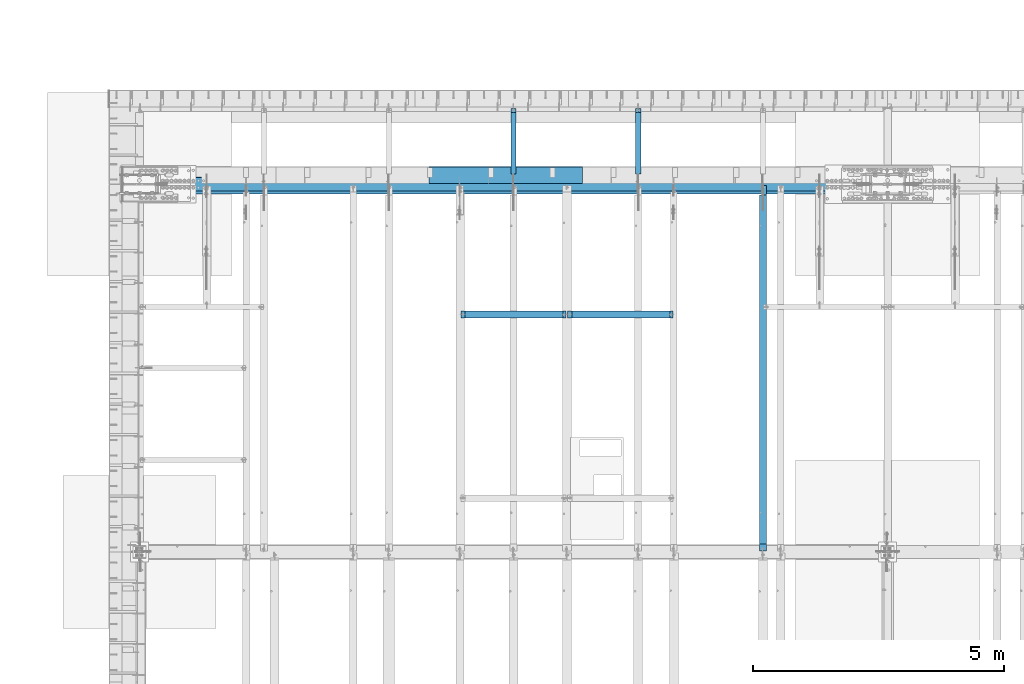
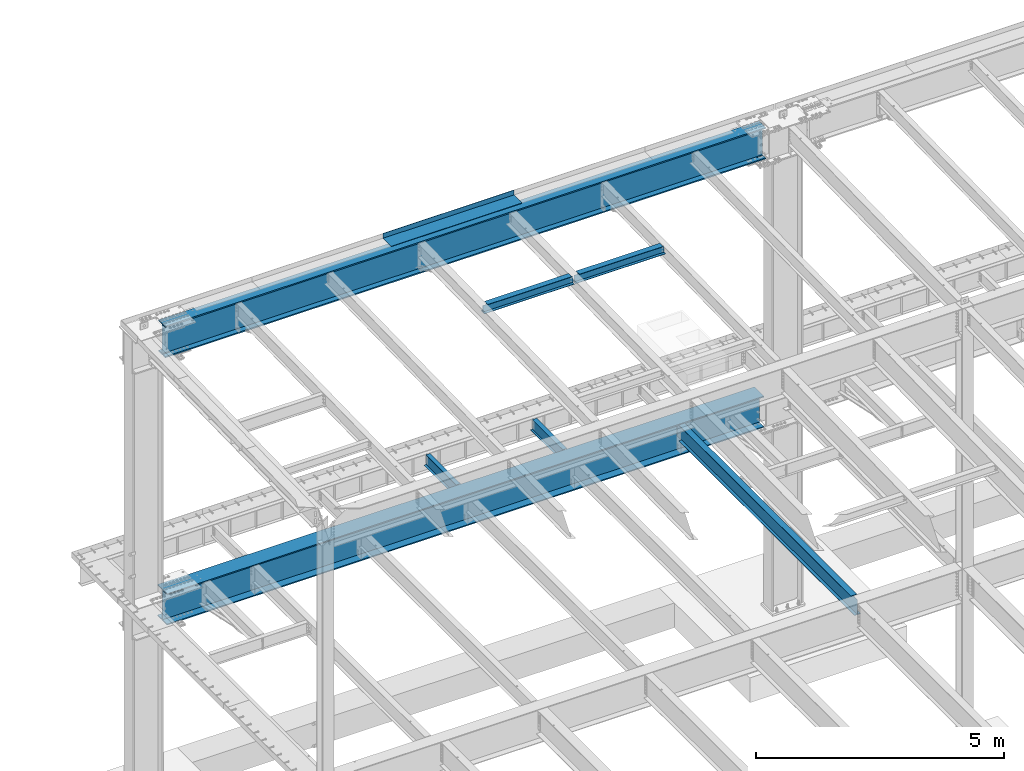
# One storey, part 1127 of 1763: 8 beams, 7 elements without a shape of their own.
"""IFC2X3 building model written with IfcOpenShell, lengths in millimetres."""

from ifc_helpers import new_model, si_unit, frame, origin_with_axes, place, context, subcontext, project, spatial, faceted_brep, material, type_object, element, aggregate, save


model = new_model("IFC2X3")

# Units and contexts
model_context = context("Model", 3, precision=1e-05, world=origin_with_axes())
body_context = subcontext(model_context, "Body", "Model", "MODEL_VIEW")
ifc_project = project(units=[si_unit("LENGTHUNIT", "METRE", prefix="MILLI"), si_unit("AREAUNIT", "SQUARE_METRE"), si_unit("VOLUMEUNIT", "CUBIC_METRE"), si_unit("MASSUNIT", "GRAM", prefix="KILO"), si_unit("TIMEUNIT", "SECOND"), si_unit("PLANEANGLEUNIT", "RADIAN"), si_unit("SOLIDANGLEUNIT", "STERADIAN"), si_unit("THERMODYNAMICTEMPERATUREUNIT", "DEGREE_CELSIUS"), si_unit("LUMINOUSINTENSITYUNIT", "LUMEN")], contexts=[model_context])

# Site, building, storey
site_placement = place(None, origin_with_axes())
site = spatial("IfcSite", under=ifc_project, at=site_placement, CompositionType="ELEMENT")
building_placement = place(site_placement, origin_with_axes())
building = spatial("IfcBuilding", under=site, at=building_placement, Name="Undefined", CompositionType="ELEMENT")
storey_placement = place(building_placement, origin_with_axes())
storey = spatial("IfcBuildingStorey", under=building, at=storey_placement, Name="Undefined", CompositionType="ELEMENT", Elevation=0.0)

# Assembly, beam
assembly_1_placement = place(storey_placement, origin_with_axes())
assembly_1 = element("IfcElementAssembly", 1, at=assembly_1_placement, inside=storey, Name="BEAM", AssemblyPlace="NOTDEFINED", PredefinedType="RIGID_FRAME")
ifc_material_1 = material(Name="STEEL/A992")
beam_type_1 = type_object("IfcBeamType", Name="W8X18", PredefinedType="NOTDEFINED")
beam_1_placement = place(assembly_1_placement, frame((-80902.2926318412, 49529.603125, 11592.1111170495), z_axis=(0.0, 0.0, 1.0), x_axis=(1.0, 0.0, 0.0)))
beam_1 = element("IfcBeam", 2, at=beam_1_placement, type_object=beam_type_1, material=ifc_material_1, Name="BEAM", ObjectType="W8X18", context=body_context, shape_type="Brep", body=[
    faceted_brep([(1960.42688668017, -3.17500000386644, 68.5472454981009), (1960.42688668019, 3.1749999961321, 68.5472454981009), (1959.56590192083, 3.17499999613938, 69.8358002505338), (1959.56590177228, -3.17500000385917, 69.8358004728379), (1964.54706314833, -3.17500000387372, 65.7942315976234), (1964.54706314833, 3.17499999612482, 65.7942315976234), (1969.40714266637, -3.175000003881, 64.8275016750358), (1969.40714266639, 3.17499999611755, 64.8275016750358), (2015.44464294919, -3.17500000397558, 64.8275016750358), (2015.44464276504, 3.17499999602296, 64.8275016750358), (1958.83938981475, -3.17500000385917, 70.3212402430472), (1958.83938963059, 3.17499999613938, 70.3212402430472), (1956.08637573011, 3.17499999613938, 74.4414167112009), (1956.08637591427, -3.17500000385917, 74.4414167112009), (1955.11964580753, 3.17499999614665, 79.3014962292473), (1955.11964599168, -3.17500000385917, 79.3014962292473), (3.17499685616349, 3.17499999998836, 95.25), (3.17499501466227, 66.6749999999884, 95.25), (1955.11964396603, 66.6749999961467, 95.25), (1955.11964580753, 3.17499999614665, 95.25), (3.17499888181919, -66.6750000000102, 103.1875), (3.17499888181919, -66.6750000000102, 95.25), (1955.11964783318, -66.6750000038592, 95.25), (1955.11964783318, -66.6750000038592, 103.1875), (3.17499501466227, 66.6749999999884, 103.1875), (1955.11964396603, 66.6749999961467, 103.1875), (1955.11964599168, -3.17500000385917, 95.25), (3.17499704031798, -3.17500000001019, 95.25), (3.17499685616349, 3.17499999998836, 79.3014961863064), (3.17499704031798, -3.17500000001019, 79.3014961863064), (2.20826693357958, 3.17499999998836, 74.44141666826), (2.20826711773407, -3.17500000001019, 74.44141666826), (-0.544746966901585, 3.17499999999563, 70.3212402001063), (-0.544746782747097, -3.17500000000291, 70.3212402001063), (-1.27125895427889, 3.17499999999563, 69.83580040995), (-1.27125910282484, -3.17500000000291, 69.8358001876459), (-2.13224382305634, 3.17499999999563, 68.5472454937626), (-2.13224382307089, -3.17500000000291, 68.5472454937626), (-6.25242029121728, 3.17500000001019, 65.7942315932851), (-6.25242029121728, -3.17499999998836, 65.7942315932851), (-11.1124998092564, 3.17500000001746, 64.8275016706975), (-11.112499809271, -3.17499999998108, 64.8275016706975), (-79.3750000920845, 3.17500000014843, 64.8275016706975), (-79.37499990793, -3.17499999985012, 64.8275016706975), (-79.3750000920845, 3.17500000014843, -95.25), (-79.3750019335857, 66.6750000001484, -95.25), (-79.3750019335857, 66.6750000001484, -103.1875), (-79.3749980664288, -66.6749999998501, -103.1875), (-79.3749980664288, -66.6749999998501, -95.25), (-79.37499990793, -3.17499999985012, -95.25), (2015.44464276504, 3.17499999602296, -95.25), (2015.44464092355, 66.674999996023, -95.25), (2015.44464092355, 66.674999996023, -103.1875), (2015.4446447907, -66.6750000039756, -103.1875), (2015.4446447907, -66.6750000039756, -95.25), (2015.44464294919, -3.17500000397558, -95.25)], [[[0, 1, 2, 3]], [[4, 5, 1, 0]], [[6, 7, 5, 4]], [[8, 9, 7, 6]], [[10, 11, 12, 13]], [[13, 12, 14, 15]], [[16, 17, 18, 19]], [[20, 21, 22, 23]], [[24, 20, 23, 25]], [[17, 24, 25, 18]], [[23, 22, 26, 15, 14, 19, 18, 25]], [[21, 27, 26, 22]], [[20, 24, 17, 16, 28, 29, 27, 21]], [[29, 28, 30, 31]], [[31, 30, 32, 33]], [[33, 32, 34, 35]], [[35, 34, 36, 37]], [[37, 36, 38, 39]], [[39, 38, 40, 41]], [[41, 40, 42, 43]], [[44, 45, 46, 47, 48, 49, 43, 42]], [[45, 44, 50, 51]], [[46, 45, 51, 52]], [[47, 46, 52, 53]], [[48, 47, 53, 54]], [[49, 48, 54, 55]], [[4, 0, 3, 10, 13, 15, 26, 27, 29, 31, 33, 35, 37, 39, 41, 43, 49, 55, 8, 6]], [[11, 10, 3, 2]], [[50, 44, 42, 40, 38, 36, 34, 32, 30, 28, 16, 19, 14, 12, 11, 2, 1, 5, 7, 9]], [[55, 54, 53, 52, 51, 50, 9, 8]]]),
])
aggregate(assembly_1, [beam_1])

assembly_2_placement = place(storey_placement, origin_with_axes())
assembly_2 = element("IfcElementAssembly", 3, at=assembly_2_placement, inside=storey, Name="BEAM", AssemblyPlace="NOTDEFINED", PredefinedType="RIGID_FRAME")
beam_2_placement = place(assembly_2_placement, frame((-78775.0426318412, 49529.603125, 11592.1111170495), z_axis=(0.0, 0.0, 1.0), x_axis=(1.0, 0.0, 0.0)))
beam_2 = element("IfcBeam", 4, at=beam_2_placement, type_object=beam_type_1, material=ifc_material_1, Name="BEAM", ObjectType="W8X18", context=body_context, shape_type="Brep", body=[
    faceted_brep([(1960.42688668017, -3.17500000386644, 68.5472454981009), (1960.42688668019, 3.1749999961321, 68.5472454981009), (1959.56590192083, 3.17499999613938, 69.8358002505338), (1959.56590177228, -3.17500000385917, 69.8358004728379), (1964.54706314833, -3.17500000387372, 65.7942315976234), (1964.54706314833, 3.17499999612482, 65.7942315976234), (1969.40714266637, -3.175000003881, 64.8275016750358), (1969.40714266639, 3.17499999611755, 64.8275016750358), (2015.44464294919, -3.17500000397558, 64.8275016750358), (2015.44464276504, 3.17499999602296, 64.8275016750358), (1958.83938981475, -3.17500000385917, 70.3212402430472), (1958.83938963059, 3.17499999613938, 70.3212402430472), (1956.08637573011, 3.17499999613938, 74.4414167112009), (1956.08637591427, -3.17500000385917, 74.4414167112009), (1955.11964580753, 3.17499999614665, 79.3014962292473), (1955.11964599168, -3.17500000385917, 79.3014962292473), (3.17499685616349, 3.17499999998836, 95.25), (3.17499501466227, 66.6749999999884, 95.25), (1955.11964396603, 66.6749999961467, 95.25), (1955.11964580753, 3.17499999614665, 95.25), (3.17499888181919, -66.6750000000102, 103.1875), (3.17499888181919, -66.6750000000102, 95.25), (1955.11964783318, -66.6750000038592, 95.25), (1955.11964783318, -66.6750000038592, 103.1875), (3.17499501466227, 66.6749999999884, 103.1875), (1955.11964396603, 66.6749999961467, 103.1875), (1955.11964599168, -3.17500000385917, 95.25), (3.17499704031798, -3.17500000001019, 95.25), (3.17499685616349, 3.17499999998836, 79.3014961863064), (3.17499704031798, -3.17500000001019, 79.3014961863064), (2.20826693357958, 3.17499999998836, 74.44141666826), (2.20826711773407, -3.17500000001019, 74.44141666826), (-0.544746966901585, 3.17499999999563, 70.3212402001063), (-0.544746782747097, -3.17500000000291, 70.3212402001063), (-1.27125895427889, 3.17499999999563, 69.83580040995), (-1.27125910282484, -3.17500000000291, 69.8358001876459), (-2.13224382305634, 3.17499999999563, 68.5472454937626), (-2.13224382307089, -3.17500000000291, 68.5472454937626), (-6.25242029121728, 3.17500000001019, 65.7942315932851), (-6.25242029121728, -3.17499999998836, 65.7942315932851), (-11.1124998092564, 3.17500000001746, 64.8275016706975), (-11.112499809271, -3.17499999998108, 64.8275016706975), (-79.3750000920845, 3.17500000014843, 64.8275016706975), (-79.37499990793, -3.17499999985012, 64.8275016706975), (-79.3750000920845, 3.17500000014843, -95.25), (-79.3750019335857, 66.6750000001484, -95.25), (-79.3750019335857, 66.6750000001484, -103.1875), (-79.3749980664288, -66.6749999998501, -103.1875), (-79.3749980664288, -66.6749999998501, -95.25), (-79.37499990793, -3.17499999985012, -95.25), (2015.44464276504, 3.17499999602296, -95.25), (2015.44464092355, 66.674999996023, -95.25), (2015.44464092355, 66.674999996023, -103.1875), (2015.4446447907, -66.6750000039756, -103.1875), (2015.4446447907, -66.6750000039756, -95.25), (2015.44464294919, -3.17500000397558, -95.25)], [[[0, 1, 2, 3]], [[4, 5, 1, 0]], [[6, 7, 5, 4]], [[8, 9, 7, 6]], [[10, 11, 12, 13]], [[13, 12, 14, 15]], [[16, 17, 18, 19]], [[20, 21, 22, 23]], [[24, 20, 23, 25]], [[17, 24, 25, 18]], [[23, 22, 26, 15, 14, 19, 18, 25]], [[21, 27, 26, 22]], [[20, 24, 17, 16, 28, 29, 27, 21]], [[29, 28, 30, 31]], [[31, 30, 32, 33]], [[33, 32, 34, 35]], [[35, 34, 36, 37]], [[37, 36, 38, 39]], [[39, 38, 40, 41]], [[41, 40, 42, 43]], [[44, 45, 46, 47, 48, 49, 43, 42]], [[45, 44, 50, 51]], [[46, 45, 51, 52]], [[47, 46, 52, 53]], [[48, 47, 53, 54]], [[49, 48, 54, 55]], [[4, 0, 3, 10, 13, 15, 26, 27, 29, 31, 33, 35, 37, 39, 41, 43, 49, 55, 8, 6]], [[11, 10, 3, 2]], [[50, 44, 42, 40, 38, 36, 34, 32, 30, 28, 16, 19, 14, 12, 11, 2, 1, 5, 7, 9]], [[55, 54, 53, 52, 51, 50, 9, 8]]]),
])
aggregate(assembly_2, [beam_2])

assembly_3_placement = place(storey_placement, origin_with_axes())
assembly_3 = element("IfcElementAssembly", 5, at=assembly_3_placement, inside=storey, Name="BEAM", AssemblyPlace="NOTDEFINED", PredefinedType="RIGID_FRAME")
beam_type_2 = type_object("IfcBeamType", Name="W16X26", PredefinedType="NOTDEFINED")
beam_3_placement = place(assembly_3_placement, frame((-74971.7706070317, 44805.6, 4994.275), z_axis=(0.0, 0.0, 1.0), x_axis=(0.0, 1.0, 0.0)))
beam_3 = element("IfcBeam", 6, at=beam_3_placement, type_object=beam_type_2, material=ifc_material_1, Name="BEAM", ObjectType="W16X26", context=body_context, shape_type="Brep", body=[
    faceted_brep([(7104.06248869727, 3.17500000000291, -190.5), (7104.06248869734, 3.17487653380522, -200.025), (7104.06247902929, 69.8499999999985, -200.025), (7104.06247902929, 69.8499999999985, -190.5), (7294.5625, 3.17500000000291, -190.5), (7294.5625, 3.17490415680368, -200.025), (159.543749432261, 3.17500000000291, 190.5), (159.543749432261, 69.8499999999985, 190.5), (7104.0625, 69.8499999999985, 190.5), (7104.0625, 3.17500000000291, 190.5), (159.543749432261, -69.8499999999985, 200.025), (159.543749432261, 69.8499999999985, 200.025), (159.543749432261, 3.17500000000291, 180.715001487732), (159.543749432261, -3.17500000000291, 180.715001487732), (159.543749432261, -3.17500000000291, 190.5), (159.543749432261, -69.8499999999985, 190.5), (158.57701950967, 3.17500000000291, 175.854921969686), (158.57701950967, -3.17500000000291, 175.854921969686), (155.824005609196, 3.17500000000291, 171.734745501532), (155.824005609196, -3.17500000000291, 171.734745501532), (151.703829141043, 3.17500000000291, 168.981731601054), (151.703829141043, -3.17500000000291, 168.981731601054), (146.843749622996, 3.17500000000291, 168.015001678466), (146.843749622996, -3.17500000000291, 168.015001678466), (19.84375, 3.17500000000291, 168.015001678466), (19.84375, -3.17500000000291, 168.015001678466), (19.84375, 3.17500000000291, -190.5), (19.84375, 69.8499999999985, -190.5), (19.84375, 69.8499999999985, -200.025), (19.84375, -69.8499999999985, -200.025), (19.84375, -69.8499999999985, -190.5), (19.84375, -3.17500000000291, -190.5), (7294.5625, -69.8499999999985, -200.025), (7294.5625, -69.8499999999985, -190.5), (7294.5625, -3.17500000000291, -190.5), (7111.90242029122, -3.17500000000291, 156.541729922587), (7107.78224382307, -3.17500000000291, 159.294743823066), (7105.02922992258, -3.17500000000291, 163.414920291219), (7104.0625, -3.17500000000291, 168.274999809265), (7104.0625, -3.17500000000291, 190.5), (7294.5625, -3.17500000000291, 155.575), (7116.76249980927, -3.17500000000291, 155.575), (7104.0625, -69.8499999999985, 190.5), (7104.0625, -69.8499999999985, 200.025), (7104.0625, 69.8499999999985, 200.025), (7104.0625, 3.17500000000291, 168.274999809265), (7105.02922992258, 3.17500000000291, 163.414920291219), (7107.78224382307, 3.17500000000291, 159.294743823066), (7111.90242029122, 3.17500000000291, 156.541729922587), (7116.76249980927, 3.17500000000291, 155.575), (7294.5625, 3.17500000000291, 155.575), (7294.5625, 3.17500000000291, -184.976846570121)], [[[0, 1, 2, 3]], [[4, 5, 1, 0]], [[6, 7, 8, 9]], [[10, 11, 7, 6, 12, 13, 14, 15]], [[13, 12, 16, 17]], [[17, 16, 18, 19]], [[19, 18, 20, 21]], [[21, 20, 22, 23]], [[23, 22, 24, 25]], [[26, 27, 28, 29, 30, 31, 25, 24]], [[30, 29, 32, 33]], [[31, 30, 33, 34]], [[35, 36, 37, 38, 39, 14, 13, 17, 19, 21, 23, 25, 31, 34, 40, 41]], [[15, 14, 39, 42]], [[10, 15, 42, 43]], [[11, 10, 43, 44]], [[7, 11, 44, 8]], [[43, 42, 39, 38, 45, 9, 8, 44]], [[37, 46, 45, 38]], [[36, 47, 46, 37]], [[35, 48, 47, 36]], [[41, 49, 48, 35]], [[40, 50, 49, 41]], [[51, 4, 0, 26, 24, 22, 20, 18, 16, 12, 6, 9, 45, 46, 47, 48, 49, 50]], [[27, 26, 0, 3]], [[28, 27, 3, 2]], [[32, 29, 28, 2, 1, 5]], [[51, 50, 40, 34, 33, 32, 5, 4]]]),
])
aggregate(assembly_3, [beam_3])

assembly_4_placement = place(storey_placement, origin_with_axes())
assembly_4 = element("IfcElementAssembly", 7, at=assembly_4_placement, inside=storey, Name="BEAM", AssemblyPlace="NOTDEFINED", PredefinedType="RIGID_FRAME")
ifc_material_2 = material(Name="STEEL/A36")
beam_type_3 = type_object("IfcBeamType", PredefinedType="NOTDEFINED")
beam_4_placement = place(assembly_4_placement, frame((-80087.2247736984, 52133.5000002128, 11752.2624917654), z_axis=(-1.0, 0.0, 0.0), x_axis=(0.0, 1.0, 0.0)))
beam_4 = element("IfcBeam", 8, at=beam_4_placement, type_object=beam_type_3, material=ifc_material_2, Name="BENT_PLATE", context=body_context, shape_type="Brep", body=[
    faceted_brep([(0.0, -4.76249999999982, -1524.0), (0.0, -4.76249999999982, 1524.0), (0.0, 4.76249999999982, 1524.0), (0.0, 4.76249999999982, -1524.0), (336.549987792969, 4.76250000000073, 1524.0), (336.549987792969, 4.76250000000073, -1524.0), (327.024987792975, -4.76250000000073, -1524.0), (327.024987792967, -4.76250000000073, 1524.00000000001), (336.549987792969, -122.237499999999, 1524.0), (336.549987792969, -122.237499999999, -1524.0), (327.024987792975, -122.237499999999, 1524.0), (327.024987792975, -122.237499999999, -1524.0)], [[[0, 1, 2, 3]], [[3, 2, 4, 5]], [[1, 0, 6, 7]], [[5, 4, 8, 9]], [[4, 2, 1, 7, 10, 8]], [[7, 6, 11, 10]], [[6, 0, 3, 5, 9, 11]], [[10, 11, 9, 8]]]),
])

assembly_5_placement = place(storey_placement, origin_with_axes())
assembly_5 = element("IfcElementAssembly", 9, at=assembly_5_placement, inside=storey, Name="BEAM", AssemblyPlace="NOTDEFINED", PredefinedType="RIGID_FRAME")
beam_type_4 = type_object("IfcBeamType", Name="W12X16", PredefinedType="NOTDEFINED")
beam_5_placement = place(assembly_5_placement, frame((-77452.6362320317, 52120.8, 5041.9), z_axis=(0.0, 0.0, 1.0), x_axis=(0.0, 1.0, 0.0)))
beam_5 = element("IfcBeam", 10, at=beam_5_placement, type_object=beam_type_4, material=ifc_material_1, Name="BEAM", ObjectType="W12X16", context=body_context, shape_type="Brep", body=[
    faceted_brep([(20.6374999999971, -3.17500000000291, -114.3), (20.6374999999971, 3.17500000000291, -114.3), (192.087500190733, 3.17500000000291, -114.3), (192.087500190733, -3.17500000000291, -114.3), (196.94757970878, 3.17500000000291, -115.266729922588), (196.94757970878, -3.17500000000291, -115.266729922588), (201.067756176933, 3.17500000000291, -118.019743823066), (201.067756176933, -3.17500000000291, -118.019743823066), (203.820770077407, 3.17500000000291, -122.13992029122), (203.820770077407, -3.17500000000291, -122.13992029122), (204.787499999999, -3.17500000000291, -126.999999809265), (204.787499999999, 3.17500000000291, -126.999999809265), (204.787499999999, 3.17500000000291, -146.05), (204.787499999999, 50.8000000000029, -146.05), (204.787499999999, 50.8000000000029, -152.4), (204.787499999999, -50.8000000000029, -152.4), (204.787499999999, -50.8000000000029, -146.05), (204.787499999999, -3.17500000000291, -146.05), (1431.13125000001, 50.8000000000029, 146.05), (1431.13125000001, 3.17500000000291, 146.05), (204.787499999999, 3.17500000000291, 146.05), (204.787499999999, 50.8000000000029, 146.05), (192.087500190733, -3.17500000000291, 114.3), (192.087500190733, 3.17500000000291, 114.3), (20.6374999999971, 3.17500000000291, 114.3), (20.6374999999971, -3.17500000000291, 114.3), (196.94757970878, -3.17500000000291, 115.266729922588), (196.94757970878, 3.17500000000291, 115.266729922588), (201.067756176933, -3.17500000000291, 118.019743823066), (201.067756176933, 3.17500000000291, 118.019743823066), (203.820770077407, -3.17500000000291, 122.13992029122), (203.820770077407, 3.17500000000291, 122.13992029122), (204.787499999999, -3.17500000000291, 126.999999809265), (204.787499999999, 3.17500000000291, 126.999999809265), (1431.13125000001, -50.8000000000029, 152.4), (1431.13125000001, 50.8000000000029, 152.4), (204.787499999999, 50.8000000000029, 152.4), (204.787499999999, -50.8000000000029, 152.4), (1431.13125000001, -50.8000000000029, 146.05), (204.787499999999, -50.8000000000029, 146.05), (1431.13125000001, -3.17500000000291, 146.05), (204.787499999999, -3.17500000000291, 146.05), (1431.13125000001, -3.17500000000291, 139.440001487732), (1431.13125000001, 3.17500000000291, 139.440001487732), (1432.0979799226, -3.17500000000291, 134.579921969686), (1432.0979799226, 3.17500000000291, 134.579921969686), (1434.85099382307, -3.17500000000291, 130.459745501533), (1434.85099382307, 3.17500000000291, 130.459745501533), (1438.97117029122, -3.17500000000291, 127.706731601054), (1438.97117029122, 3.17500000000291, 127.706731601054), (1443.83124980927, -3.17500000000291, 126.740001678467), (1443.83124980927, 3.17500000000291, 126.740001678467), (1507.33125, -3.17500000000291, 126.740001678467), (1507.33125, 3.17500000000291, 126.740001678467), (1507.33125, -3.17500000000291, -146.05), (1507.33125, -50.8000000000029, -146.05), (1507.33125, -50.8000000000029, -152.4), (1507.33125, 50.8000000000029, -152.4), (1507.33125, 50.8000000000029, -146.05), (1507.33125, 3.17500000000291, -146.05)], [[[0, 1, 2, 3]], [[3, 2, 4, 5]], [[5, 4, 6, 7]], [[7, 6, 8, 9]], [[10, 11, 12, 13, 14, 15, 16, 17]], [[9, 8, 11, 10]], [[18, 19, 20, 21]], [[22, 23, 24, 25]], [[26, 27, 23, 22]], [[28, 29, 27, 26]], [[30, 31, 29, 28]], [[32, 33, 31, 30]], [[34, 35, 36, 37]], [[38, 34, 37, 39]], [[40, 38, 39, 41]], [[37, 36, 21, 20, 33, 32, 41, 39]], [[35, 18, 21, 36]], [[34, 38, 40, 42, 43, 19, 18, 35]], [[44, 45, 43, 42]], [[46, 47, 45, 44]], [[48, 49, 47, 46]], [[50, 51, 49, 48]], [[52, 53, 51, 50]], [[54, 55, 56, 57, 58, 59, 53, 52]], [[55, 54, 17, 16]], [[56, 55, 16, 15]], [[57, 56, 15, 14]], [[58, 57, 14, 13]], [[59, 58, 13, 12]], [[6, 4, 2, 1, 24, 23, 27, 29, 31, 33, 20, 19, 43, 45, 47, 49, 51, 53, 59, 12, 11, 8]], [[25, 24, 1, 0]], [[54, 52, 50, 48, 46, 44, 42, 40, 41, 32, 30, 28, 26, 22, 25, 0, 3, 5, 7, 9, 10, 17]]]),
])
aggregate(assembly_5, [beam_5])

assembly_6_placement = place(storey_placement, origin_with_axes())
assembly_6 = element("IfcElementAssembly", 11, at=assembly_6_placement, inside=storey, Name="BEAM", AssemblyPlace="NOTDEFINED", PredefinedType="RIGID_FRAME")
beam_6_placement = place(assembly_6_placement, frame((-79933.2372736984, 52120.8, 5041.9), z_axis=(0.0, 0.0, 1.0), x_axis=(0.0, 1.0, 0.0)))
beam_6 = element("IfcBeam", 12, at=beam_6_placement, type_object=beam_type_4, material=ifc_material_1, Name="BEAM", ObjectType="W12X16", context=body_context, shape_type="Brep", body=[
    faceted_brep([(20.6374999999971, -3.17500000000291, -114.3), (20.6374999999971, 3.17500000000291, -114.3), (192.087500190733, 3.17500000000291, -114.3), (192.087500190733, -3.17500000000291, -114.3), (196.94757970878, 3.17500000000291, -115.266729922588), (196.94757970878, -3.17500000000291, -115.266729922588), (201.067756176933, 3.17500000000291, -118.019743823066), (201.067756176933, -3.17500000000291, -118.019743823066), (203.820770077407, 3.17500000000291, -122.13992029122), (203.820770077407, -3.17500000000291, -122.13992029122), (204.787499999999, -3.17500000000291, -126.999999809265), (204.787499999999, 3.17500000000291, -126.999999809265), (204.787499999999, 3.17500000000291, -146.05), (204.787499999999, 50.8000000000029, -146.05), (204.787499999999, 50.8000000000029, -152.4), (204.787499999999, -50.8000000000029, -152.4), (204.787499999999, -50.8000000000029, -146.05), (204.787499999999, -3.17500000000291, -146.05), (1431.13125000001, 50.8000000000029, 146.05), (1431.13125000001, 3.17500000000291, 146.05), (204.787499999999, 3.17500000000291, 146.05), (204.787499999999, 50.8000000000029, 146.05), (192.087500190733, -3.17500000000291, 114.3), (192.087500190733, 3.17500000000291, 114.3), (20.6374999999971, 3.17500000000291, 114.3), (20.6374999999971, -3.17500000000291, 114.3), (196.94757970878, -3.17500000000291, 115.266729922588), (196.94757970878, 3.17500000000291, 115.266729922588), (201.067756176933, -3.17500000000291, 118.019743823066), (201.067756176933, 3.17500000000291, 118.019743823066), (203.820770077407, -3.17500000000291, 122.13992029122), (203.820770077407, 3.17500000000291, 122.13992029122), (204.787499999999, -3.17500000000291, 126.999999809265), (204.787499999999, 3.17500000000291, 126.999999809265), (1431.13125000001, -50.8000000000029, 152.4), (1431.13125000001, 50.8000000000029, 152.4), (204.787499999999, 50.8000000000029, 152.4), (204.787499999999, -50.8000000000029, 152.4), (1431.13125000001, -50.8000000000029, 146.05), (204.787499999999, -50.8000000000029, 146.05), (1431.13125000001, -3.17500000000291, 146.05), (204.787499999999, -3.17500000000291, 146.05), (1431.13125000001, -3.17500000000291, 139.440001487732), (1431.13125000001, 3.17500000000291, 139.440001487732), (1432.0979799226, -3.17500000000291, 134.579921969686), (1432.0979799226, 3.17500000000291, 134.579921969686), (1434.85099382307, -3.17500000000291, 130.459745501533), (1434.85099382307, 3.17500000000291, 130.459745501533), (1438.97117029122, -3.17500000000291, 127.706731601054), (1438.97117029122, 3.17500000000291, 127.706731601054), (1443.83124980927, -3.17500000000291, 126.740001678467), (1443.83124980927, 3.17500000000291, 126.740001678467), (1507.33125, -3.17500000000291, 126.740001678467), (1507.33125, 3.17500000000291, 126.740001678467), (1507.33125, -3.17500000000291, -146.05), (1507.33125, -50.8000000000029, -146.05), (1507.33125, -50.8000000000029, -152.4), (1507.33125, 50.8000000000029, -152.4), (1507.33125, 50.8000000000029, -146.05), (1507.33125, 3.17500000000291, -146.05)], [[[0, 1, 2, 3]], [[3, 2, 4, 5]], [[5, 4, 6, 7]], [[7, 6, 8, 9]], [[10, 11, 12, 13, 14, 15, 16, 17]], [[9, 8, 11, 10]], [[18, 19, 20, 21]], [[22, 23, 24, 25]], [[26, 27, 23, 22]], [[28, 29, 27, 26]], [[30, 31, 29, 28]], [[32, 33, 31, 30]], [[34, 35, 36, 37]], [[38, 34, 37, 39]], [[40, 38, 39, 41]], [[37, 36, 21, 20, 33, 32, 41, 39]], [[35, 18, 21, 36]], [[34, 38, 40, 42, 43, 19, 18, 35]], [[44, 45, 43, 42]], [[46, 47, 45, 44]], [[48, 49, 47, 46]], [[50, 51, 49, 48]], [[52, 53, 51, 50]], [[54, 55, 56, 57, 58, 59, 53, 52]], [[55, 54, 17, 16]], [[56, 55, 16, 15]], [[57, 56, 15, 14]], [[58, 57, 14, 13]], [[59, 58, 13, 12]], [[6, 4, 2, 1, 24, 23, 27, 29, 31, 33, 20, 19, 43, 45, 47, 49, 51, 53, 59, 12, 11, 8]], [[25, 24, 1, 0]], [[54, 52, 50, 48, 46, 44, 42, 40, 41, 32, 30, 28, 26, 22, 25, 0, 3, 5, 7, 9, 10, 17]]]),
])
aggregate(assembly_6, [beam_6])

assembly_7_placement = place(storey_placement, origin_with_axes())
assembly_7 = element("IfcElementAssembly", 13, at=assembly_7_placement, inside=storey, Name="BEAM", AssemblyPlace="NOTDEFINED", PredefinedType="RIGID_FRAME")
beam_type_5 = type_object("IfcBeamType", Name="W30X173", PredefinedType="NOTDEFINED")
beam_7_placement = place(assembly_7_placement, frame((-87375.4372736983, 52120.8, 4806.95), z_axis=(0.0, 0.0, 1.0), x_axis=(1.0, 0.0, 0.0)))
beam_7 = element("IfcBeam", 14, at=beam_7_placement, type_object=beam_type_5, material=ifc_material_1, Name="BEAM", ObjectType="W30X173", context=body_context, shape_type="Brep", body=[
    faceted_brep([(430.212500000009, 41.2750003814726, -360.3625), (430.212500000009, 41.2750003814726, -387.35), (568.324999809265, 41.2750003814726, -387.35), (568.324999809265, 41.2750003814726, -360.3625), (572.577569524408, 40.4291116719833, -387.35), (572.577569524408, 40.4291116719833, -360.3625), (576.182724050072, 38.0202244315442, -387.35), (576.182724050072, 38.0202244315442, -360.3625), (578.591611290511, 34.4150699058882, -387.35), (578.591611290511, 34.4150699058882, -360.3625), (568.324999809265, 19.0500000000029, -360.3625), (568.324999809265, 19.0500000000029, -387.35), (430.212500000009, 19.0500000000029, -387.35), (430.212500000009, 19.0500000000029, -360.3625), (572.577569524408, 19.8958887094923, -360.3625), (572.577569524408, 19.8958887094923, -387.35), (576.182724050072, 22.3047759499314, -360.3625), (576.182724050072, 22.3047759499314, -387.35), (578.591611290511, 25.9099304755873, -360.3625), (578.591611290511, 25.9099304755873, -387.35), (579.4375, 30.1625001907378, -360.3625), (579.4375, 30.1625001907378, -387.35), (430.212500000009, 7.9375, 360.3625), (430.212500000009, 190.5, 360.3625), (14327.1875, 190.5, 360.3625), (14327.1875, 7.9375, 360.3625), (430.212500000009, 190.5, 387.35), (14327.1875, 190.5, 387.35), (430.212500000009, -190.5, 387.35), (14327.1875, -190.5, 387.35), (430.212500000009, -190.5, 360.3625), (14327.1875, -190.5, 360.3625), (430.212500000009, -7.9375, 360.3625), (14327.1875, -7.9375, 360.3625), (430.212500000009, -7.9375, -360.3625), (14327.1875, -7.9375, -360.3625), (430.212500000009, -190.5, -360.3625), (14327.1875, -190.5, -360.3625), (430.212500000009, -190.5, -387.35), (14327.1875, -190.5, -387.35), (430.212500000009, 190.5, -387.35), (430.212500000009, 190.5, -360.3625), (14327.1875, 190.5, -360.3625), (14327.1875, 190.5, -387.35), (14327.1875, 41.2750003814726, -360.3625), (14327.1875, 41.2750003814726, -387.35), (14189.0750001907, 41.2750003814726, -360.3625), (14189.0750001907, 41.2750003814726, -387.35), (14184.8224304756, 40.4291116719833, -360.3625), (14184.8224304756, 40.4291116719833, -387.35), (14181.2172759499, 38.0202244315442, -360.3625), (14181.2172759499, 38.0202244315442, -387.35), (14178.8083887095, 34.4150699058882, -360.3625), (14178.8083887095, 34.4150699058882, -387.35), (14177.9625, 30.1625001907378, -360.3625), (14177.9625, 30.1625001907378, -387.35), (14178.8083887095, 25.9099304755873, -360.3625), (14178.8083887095, 25.9099304755873, -387.35), (14181.2172759499, 22.3047759499314, -360.3625), (14181.2172759499, 22.3047759499314, -387.35), (14184.8224304756, 19.8958887094923, -360.3625), (14184.8224304756, 19.8958887094923, -387.35), (14189.0750001907, 19.0500000000029, -360.3625), (14189.0750001907, 19.0500000000029, -387.35), (14327.1875, 19.0500000000029, -360.3625), (14327.1875, 19.0500000000029, -387.35), (14327.1875, 7.9375, -360.3625), (430.212500000009, 7.9375, -360.3625)], [[[0, 1, 2, 3]], [[3, 2, 4, 5]], [[5, 4, 6, 7]], [[7, 6, 8, 9]], [[10, 11, 12, 13]], [[14, 15, 11, 10]], [[16, 17, 15, 14]], [[18, 19, 17, 16]], [[20, 21, 19, 18]], [[9, 8, 21, 20]], [[22, 23, 24, 25]], [[23, 26, 27, 24]], [[26, 28, 29, 27]], [[28, 30, 31, 29]], [[30, 32, 33, 31]], [[32, 34, 35, 33]], [[34, 36, 37, 35]], [[36, 38, 39, 37]], [[40, 41, 42, 43]], [[43, 42, 44, 45]], [[44, 46, 47, 45]], [[48, 49, 47, 46]], [[50, 51, 49, 48]], [[52, 53, 51, 50]], [[54, 55, 53, 52]], [[56, 57, 55, 54]], [[58, 59, 57, 56]], [[60, 61, 59, 58]], [[62, 63, 61, 60]], [[64, 65, 63, 62]], [[66, 25, 24, 27, 29, 31, 33, 35, 37, 39, 65, 64]], [[67, 22, 25, 66]], [[38, 36, 34, 32, 30, 28, 26, 23, 22, 67, 13, 12]], [[6, 4, 2, 1, 40, 43, 45, 47, 49, 51, 53, 55, 57, 59, 61, 63, 65, 39, 38, 12, 11, 15, 17, 19, 21, 8]], [[41, 40, 1, 0]], [[16, 14, 10, 13, 67, 66, 64, 62, 60, 58, 56, 54, 52, 50, 48, 46, 44, 42, 41, 0, 3, 5, 7, 9, 20, 18]]]),
])
aggregate(assembly_7, [beam_7])

# Beam
beam_type_6 = type_object("IfcBeamType", Name="W30X148", PredefinedType="NOTDEFINED")
beam_8_placement = place(assembly_4_placement, frame((-87375.4372736983, 52120.8000002128, 11358.5624917654), z_axis=(0.0, 0.0, 1.0), x_axis=(1.0, 0.0, 0.0)))
beam_8 = element("IfcBeam", 15, at=beam_8_placement, type_object=beam_type_6, material=ifc_material_1, Name="BEAM", ObjectType="W30X148", context=body_context, shape_type="Brep", body=[
    faceted_brep([(14403.3875, -19.0500000000029, -358.775), (14262.1000001907, -19.0500000000029, -358.775), (14262.1000001907, -19.0500000000029, -388.9375), (14403.3875, -19.0500000000029, -388.9375), (14257.8474304756, -19.8958887094923, -358.775), (14257.8474304756, -19.8958887094923, -388.9375), (14254.2422759499, -22.3047759499314, -358.775), (14254.2422759499, -22.3047759499314, -388.9375), (14251.8333887095, -25.9099304755873, -358.775), (14251.8333887095, -25.9099304755873, -388.9375), (14250.9875, -30.1625001907378, -358.775), (14250.9875, -30.1625001907378, -388.9375), (14251.8333887095, -34.4150699058882, -358.775), (14251.8333887095, -34.4150699058882, -388.9375), (14254.2422759499, -38.0202244315442, -358.775), (14254.2422759499, -38.0202244315442, -388.9375), (14257.8474304756, -40.4291116719833, -358.775), (14257.8474304756, -40.4291116719833, -388.9375), (14262.1000001907, -41.2750003814726, -358.775), (14262.1000001907, -41.2750003814726, -388.9375), (14403.3875, -41.2750003814726, -358.775), (14403.3875, -41.2750003814726, -388.9375), (420.6875, -7.9375, 358.775), (420.6875, -7.9375, -358.775), (14403.3875, -7.9375, -358.775), (14403.3875, -7.9375, 358.775), (420.6875, -133.349999999999, 358.775), (14403.3875, -133.349999999999, 358.775), (420.6875, -133.349999999999, 388.9375), (14403.3875, -133.349999999999, 388.9375), (420.6875, 133.349999999999, 388.9375), (14403.3875, 133.349999999999, 388.9375), (420.6875, 133.349999999999, 358.775), (14403.3875, 133.349999999999, 358.775), (420.6875, 7.9375, 358.775), (14403.3875, 7.9375, 358.775), (420.6875, 7.9375, -358.775), (14403.3875, 7.9375, -358.775), (420.6875, 133.349999999999, -358.775), (14403.3875, 133.349999999999, -358.775), (420.6875, 133.349999999999, -388.9375), (14403.3875, 133.349999999999, -388.9375), (420.6875, -19.0500002128101, -388.9375), (420.6875, -19.0500002128101, -358.775), (561.974999809259, -19.0500002128101, -388.9375), (561.974999809259, -19.0500002128101, -358.775), (566.227569524402, -19.8958889222995, -388.9375), (566.227569524402, -19.8958889222995, -358.775), (569.832724050066, -22.3047761627386, -388.9375), (569.832724050066, -22.3047761627386, -358.775), (572.241611290505, -25.9099306883945, -388.9375), (572.241611290505, -25.9099306883945, -358.775), (573.087499999994, -30.162500403545, -388.9375), (573.087499999994, -30.162500403545, -358.775), (572.241611290505, -34.4150701186954, -388.9375), (572.241611290505, -34.4150701186954, -358.775), (569.832724050066, -38.0202246443514, -388.9375), (569.832724050066, -38.0202246443514, -358.775), (566.227569524402, -40.4291118847905, -388.9375), (566.227569524402, -40.4291118847905, -358.775), (561.974999809259, -41.2750005942798, -388.9375), (561.974999809259, -41.2750005942798, -358.775), (420.6875, -41.2750005942798, -388.9375), (420.6875, -41.2750005942798, -358.775), (420.6875, -133.349999999999, -388.9375), (420.6875, -133.349999999999, -358.775), (14403.3875, -133.349999999999, -388.9375), (14403.3875, -133.349999999999, -358.775)], [[[0, 1, 2, 3]], [[4, 5, 2, 1]], [[6, 7, 5, 4]], [[8, 9, 7, 6]], [[10, 11, 9, 8]], [[12, 13, 11, 10]], [[14, 15, 13, 12]], [[16, 17, 15, 14]], [[18, 19, 17, 16]], [[20, 21, 19, 18]], [[22, 23, 24, 25]], [[26, 22, 25, 27]], [[28, 26, 27, 29]], [[30, 28, 29, 31]], [[32, 30, 31, 33]], [[34, 32, 33, 35]], [[36, 34, 35, 37]], [[38, 36, 37, 39]], [[40, 38, 39, 41]], [[23, 22, 26, 28, 30, 32, 34, 36, 38, 40, 42, 43]], [[43, 42, 44, 45]], [[45, 44, 46, 47]], [[47, 46, 48, 49]], [[49, 48, 50, 51]], [[51, 50, 52, 53]], [[53, 52, 54, 55]], [[55, 54, 56, 57]], [[57, 56, 58, 59]], [[59, 58, 60, 61]], [[61, 60, 62, 63]], [[64, 65, 63, 62]], [[65, 64, 66, 67]], [[16, 14, 12, 10, 8, 6, 4, 1, 0, 24, 23, 43, 45, 47, 49, 51, 53, 55, 57, 59, 61, 63, 65, 67, 20, 18]], [[41, 39, 37, 35, 33, 31, 29, 27, 25, 24, 0, 3]], [[66, 64, 62, 60, 58, 56, 54, 52, 50, 48, 46, 44, 42, 40, 41, 3, 2, 5, 7, 9, 11, 13, 15, 17, 19, 21]], [[67, 66, 21, 20]]]),
])

aggregate(assembly_4, [beam_4, beam_8])

save(model, "model.ifc")
